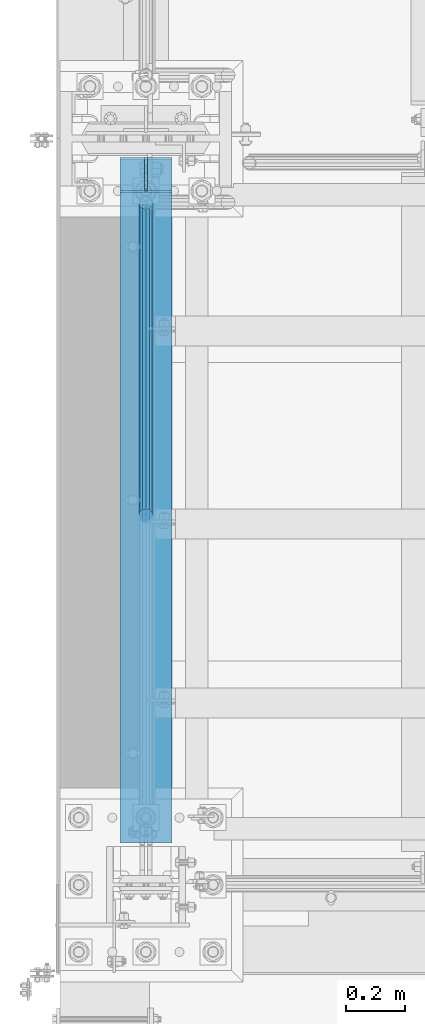
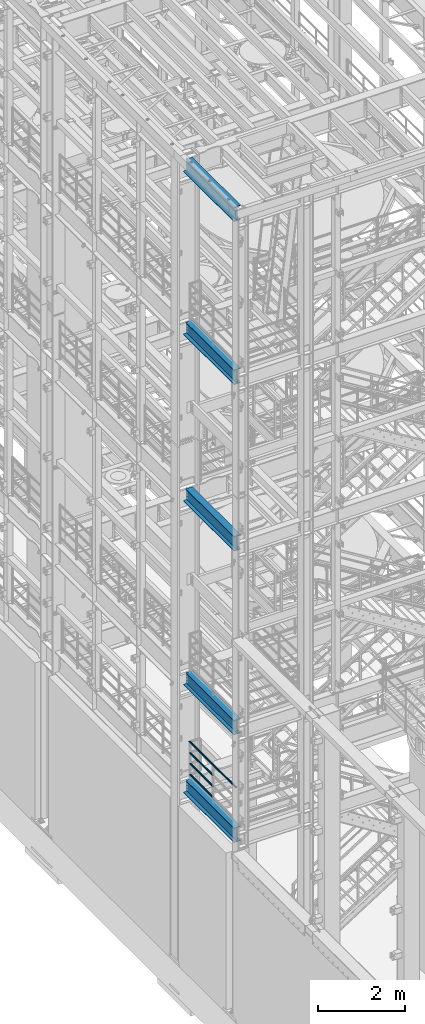
# One storey, part 953 of 1876: 9 beams, 6 elements without a shape of their own.
"""IFC2X3 building model written with IfcOpenShell, lengths in millimetres."""

import ifcopenshell
import ifcopenshell.guid

model = None  # the IFC model being written
_history = None  # IfcOwnerHistory: only IFC2X3 demands one
_inside = {}  # id of a spatial element -> (the spatial element, [elements in it])
_under = {}  # id of a project, library or spatial element -> (it, [spatial elements below it])
_declared = {}  # id of a project -> (the project, [libraries it declares])
_typed = {}  # id of a type object -> (the type object, [elements of that type])
_made_of = {}  # id of a material, layer set ... -> (it, [elements and type objects made of it])


def new_model(schema):
    """Start an empty IFC model of exactly this schema.

    Asked for "IFC4X3", IfcOpenShell would pick the latest addendum, in which some entities
    have other attributes; the version numbers below select the first issue.
    IFC2X3 requires an IfcOwnerHistory on every rooted entity: one is made here for all.
    """
    global model, _history
    if schema == "IFC4X3":
        model = ifcopenshell.file(schema_version=(4, 3, 0, 0))
    else:
        model = ifcopenshell.file(schema=schema)
    _inside.clear()
    _under.clear()
    _declared.clear()
    _typed.clear()
    _made_of.clear()
    _history = None
    if model.schema == "IFC2X3":
        org = make("IfcOrganization", Name="unknown")
        user = make(
            "IfcPersonAndOrganization",
            ThePerson=make("IfcPerson", FamilyName="unknown"),
            TheOrganization=org,
        )
        app = make(
            "IfcApplication",
            ApplicationDeveloper=org,
            Version="unknown",
            ApplicationFullName="unknown",
            ApplicationIdentifier="unknown",
        )
        _history = make(
            "IfcOwnerHistory",
            OwningUser=user,
            OwningApplication=app,
            ChangeAction="ADDED",
            CreationDate=0,
        )
    return model


def make(cls, **values):
    """One entity of the class cls with the attributes given. An attribute that is None is left unset."""
    return model.create_entity(
        cls, **{name: value for name, value in values.items() if value is not None}
    )


def rooted(cls, **values):
    """An entity with a GlobalId (a new one), such as an element, a storey or a relation."""
    return make(cls, GlobalId=ifcopenshell.guid.new(), OwnerHistory=_history, **values)


def si_unit(unit_type, name, prefix=None):
    """IfcSIUnit, for example si_unit("LENGTHUNIT", "METRE", prefix="MILLI")."""
    return make("IfcSIUnit", UnitType=unit_type, Prefix=prefix, Name=name)


def assignment(units):
    """IfcUnitAssignment: the units of a project."""
    return None if units is None else make("IfcUnitAssignment", Units=units)


def point(xyz):
    """IfcCartesianPoint."""
    return None if xyz is None else make("IfcCartesianPoint", Coordinates=xyz)


def direction(xyz):
    """IfcDirection."""
    return None if xyz is None else make("IfcDirection", DirectionRatios=xyz)


def frame(location, z_axis=None, x_axis=None):
    """IfcAxis2Placement3D, a coordinate frame: its origin and axes. An axis left out is left unset."""
    return make(
        "IfcAxis2Placement3D",
        Location=point(location),
        Axis=direction(z_axis),
        RefDirection=direction(x_axis),
    )


def origin_with_axes():
    """The frame at (0, 0, 0) with the z axis (0, 0, 1) and the x axis (1, 0, 0) written out."""
    return frame((0.0, 0.0, 0.0), z_axis=(0.0, 0.0, 1.0), x_axis=(1.0, 0.0, 0.0))


def place(relative_to, where):
    """IfcLocalPlacement: puts the frame where relative to a parent placement (None: the world)."""
    return make(
        "IfcLocalPlacement", PlacementRelTo=relative_to, RelativePlacement=where
    )


def context(
    kind, dimensions, precision=None, world=None, true_north=None, identifier=None
):
    """IfcGeometricRepresentationContext, for example the 3D "Model" context."""
    return make(
        "IfcGeometricRepresentationContext",
        ContextIdentifier=identifier,
        ContextType=kind,
        CoordinateSpaceDimension=dimensions,
        Precision=precision,
        WorldCoordinateSystem=world,
        TrueNorth=true_north,
    )


def subcontext(parent, identifier, kind, view, scale=None):
    """IfcGeometricRepresentationSubContext, for example "Body" below "Model"."""
    return make(
        "IfcGeometricRepresentationSubContext",
        ContextIdentifier=identifier,
        ContextType=kind,
        ParentContext=parent,
        TargetScale=scale,
        TargetView=view,
    )


def project(units=None, contexts=None):
    """IfcProject with its units and contexts."""
    return rooted(
        "IfcProject",
        Name="project",
        RepresentationContexts=contexts,
        UnitsInContext=assignment(units),
    )


def spatial(cls, under=None, at=None, **own):
    """A site, building, storey or space (cls), placed at a placement, below another one or the project."""
    s = rooted(cls, ObjectPlacement=at, **own)
    if under is not None:
        _under.setdefault(under.id(), (under, []))[1].append(s)
    return s


def faces_of(points, faces, orient=None, outer=None):
    """IfcFace entities. A face is a list of loops; a loop is a list of indices into points, from 0.

    orient and outer hold one flag for each loop. By default every Orientation is true, the
    first loop of a face is its IfcFaceOuterBound and the others are IfcFaceBound.
    """
    made = []
    for i, loops in enumerate(faces):
        bounds = []
        for j, loop in enumerate(loops):
            is_outer = j == 0 if outer is None else outer[i][j]
            bounds.append(
                make(
                    "IfcFaceOuterBound" if is_outer else "IfcFaceBound",
                    Bound=make("IfcPolyLoop", Polygon=[points[k] for k in loop]),
                    Orientation=True if orient is None else orient[i][j],
                )
            )
        made.append(make("IfcFace", Bounds=bounds))
    return made


def faceted_brep(points, faces, orient=None, outer=None, voids=None):
    """IfcFacetedBrep: a solid bounded by flat faces; with voids (closed shells), ...WithVoids."""
    shared = [point(p) for p in points]
    hull = make("IfcClosedShell", CfsFaces=faces_of(shared, faces, orient, outer))
    if voids is None:
        return make("IfcFacetedBrep", Outer=hull)
    return make(
        "IfcFacetedBrepWithVoids",
        Outer=hull,
        Voids=[
            make(cls, CfsFaces=faces_of(shared, fs, o, b)) for cls, fs, o, b in voids
        ],
    )


def shape(context_of_items, identifier, shape_type, items):
    """IfcShapeRepresentation: the items that make up one representation, for example the "Body"."""
    return make(
        "IfcShapeRepresentation",
        ContextOfItems=context_of_items,
        RepresentationIdentifier=identifier,
        RepresentationType=shape_type,
        Items=items,
    )


def material(Name=None, Category=None):
    """IfcMaterial."""
    return make("IfcMaterial", Name=Name, Category=Category)


def made_of(thing, what):
    """Note that an element or type object is made of a material, layer set ...; save() writes the relation."""
    if what is not None:
        _made_of.setdefault(what.id(), (what, []))[1].append(thing)
    return thing


def type_object(cls, material=None, **own):
    """A type object (cls), such as IfcWallType, which elements share."""
    return made_of(rooted(cls, **own), material)


def element(
    cls,
    number,
    at=None,
    inside=None,
    cuts=None,
    type_object=None,
    material=None,
    context=None,
    identifier="Body",
    shape_type=None,
    held_by="IfcProductDefinitionShape",
    body=None,
    shapes=None,
    **own,
):
    """One element of the class cls, such as IfcWall. Its Tag is "e" and its number.

    at: its placement. inside: the storey or other place that contains it. cuts: it is an
    opening in that element (IfcRelVoidsElement). A single representation is given by context,
    identifier, shape_type and body (its items); several are given by shapes. held_by: the class
    of the entity that holds the representations. save() writes the other relations.
    """
    e = rooted(cls, Tag="e%d" % number, ObjectPlacement=at, **own)
    if body is not None:
        shapes = [shape(context, identifier, shape_type, body)]
    if shapes is not None:
        e.Representation = make(held_by, Representations=shapes)
    if inside is not None:
        _inside.setdefault(inside.id(), (inside, []))[1].append(e)
    if cuts is not None:
        rooted(
            "IfcRelVoidsElement", RelatingBuildingElement=cuts, RelatedOpeningElement=e
        )
    if type_object is not None:
        _typed.setdefault(type_object.id(), (type_object, []))[1].append(e)
    return made_of(e, material)


def aggregate(whole, parts):
    """IfcRelAggregates: a whole, such as a stair, and the parts it consists of."""
    return rooted("IfcRelAggregates", RelatingObject=whole, RelatedObjects=parts)


def save(model, path):
    """Write the relations noted so far, then the file.

    IfcRelAggregates (storeys below a building ...), IfcRelContainedInSpatialStructure (elements
    in a storey), IfcRelDefinesByType, IfcRelAssociatesMaterial and IfcRelDeclares: one each for
    every whole, place, type object, material and project.
    """
    for whole, parts in _under.values():
        aggregate(whole, parts)
    for where, things in _inside.values():
        rooted(
            "IfcRelContainedInSpatialStructure",
            RelatedElements=things,
            RelatingStructure=where,
        )
    for kind, things in _typed.values():
        rooted("IfcRelDefinesByType", RelatedObjects=things, RelatingType=kind)
    for what, things in _made_of.values():
        rooted("IfcRelAssociatesMaterial", RelatedObjects=things, RelatingMaterial=what)
    for by, libraries in _declared.values():
        rooted("IfcRelDeclares", RelatingContext=by, RelatedDefinitions=libraries)
    model.write(path)


model = new_model("IFC2X3")

# Units and contexts
model_context = context("Model", 3, precision=1e-05, world=origin_with_axes())
body_context = subcontext(model_context, "Body", "Model", "MODEL_VIEW")
ifc_project = project(units=[si_unit("LENGTHUNIT", "METRE", prefix="MILLI"), si_unit("AREAUNIT", "SQUARE_METRE"), si_unit("VOLUMEUNIT", "CUBIC_METRE"), si_unit("MASSUNIT", "GRAM", prefix="KILO"), si_unit("TIMEUNIT", "SECOND"), si_unit("PLANEANGLEUNIT", "RADIAN"), si_unit("SOLIDANGLEUNIT", "STERADIAN"), si_unit("THERMODYNAMICTEMPERATUREUNIT", "DEGREE_CELSIUS"), si_unit("LUMINOUSINTENSITYUNIT", "LUMEN")], contexts=[model_context])

# Site, building, storey
site_placement = place(None, origin_with_axes())
site = spatial("IfcSite", under=ifc_project, at=site_placement, CompositionType="ELEMENT")
building_placement = place(site_placement, origin_with_axes())
building = spatial("IfcBuilding", under=site, at=building_placement, Name="Undefined", CompositionType="ELEMENT")
storey_placement = place(building_placement, origin_with_axes())
storey = spatial("IfcBuildingStorey", under=building, at=storey_placement, Name="Undefined", CompositionType="ELEMENT", Elevation=0.0)

# Assembly, beams
assembly_1_placement = place(storey_placement, origin_with_axes())
assembly_1 = element("IfcElementAssembly", 1, at=assembly_1_placement, inside=storey, Name="RAIL", AssemblyPlace="NOTDEFINED", PredefinedType="RIGID_FRAME")
ifc_material_1 = material()
beam_type_1 = type_object("IfcBeamType", Name="PIPE1-1/2SCH40", PredefinedType="NOTDEFINED")
beam_1_placement = place(assembly_1_placement, frame((-4.25200314889665e-12, -4788.2175, 5292.725), z_axis=(0.0, 0.0, 1.0), x_axis=(0.0, -1.0, 0.0)))
beam_1 = element("IfcBeam", 2, at=beam_1_placement, type_object=beam_type_1, material=ifc_material_1, Name="RAIL", ObjectType="PIPE1-1/2SCH40", context=body_context, shape_type="Brep", body=[
    faceted_brep([(1047.96655700668, -12.0649999999996, 20.8971929933177), (1047.96655700668, -12.0649999999787, 15.8661214312015), (1047.47312856882, -10.2235000000001, 17.7076214311819), (1044.73375, 9.09494701772928e-13, 20.4470000000001), (1044.73375, 9.09494701772928e-13, 24.130000000001), (1047.47312856881, 10.2235000000001, 17.7076214311819), (1047.96655700668, 12.0650000000205, 15.8661214311578), (1047.96655700668, 12.0649999999996, 20.8971929933177), (1068.86375, 24.1300000000001, 0.0), (1056.79875, 20.8971929933186, 12.0649999999987), (1056.79875, 20.8971929933186, -12.0649999999987), (1053.60917843784, 17.7076214311801, 10.2235000000001), (1056.34855700666, 20.4470000000001, 0.0), (1053.60917843784, 17.7076214311801, -10.2235000000001), (1047.96655700668, 12.0650000000205, -15.8661214311578), (1047.96655700668, 12.0649999999996, -20.8971929933177), (1047.47312856881, 10.2235000000001, -17.7076214311819), (1044.73375, 0.0, -20.4470000000001), (1044.73375, 0.0, -24.130000000001), (1047.96655700668, -12.0649999999787, -15.8661214312015), (1047.96655700668, -12.0649999999996, -20.8971929933177), (1047.47312856882, -10.2235000000001, -17.7076214311819), (1068.86375, -24.1299999999792, 0.0), (1056.79875, -20.8971929933186, -12.0649999999987), (1056.79875, -20.8971929933186, 12.0649999999987), (1053.60917843788, -17.7076214311801, -10.2235000000001), (1056.3485570067, -20.4470000000001, 0.0), (1053.60917843788, -17.7076214311801, 10.2235000000001), (12.0650000000064, -20.8971929933177, -12.0649999999987), (20.8971929933249, -12.0650000000005, -20.8971929933177), (0.0, 24.1299999999992, 0.0), (12.0650000000064, 20.8971929933177, -12.0649999999987), (12.0650000000064, 20.8971929933177, 12.0649999999987), (20.8971929933249, 12.0650000000005, 20.8971929933177), (24.1300000000064, 0.0, 24.130000000001), (20.8971929933249, 12.0650000000005, -20.8971929933177), (24.1300000000063, 0.0, -24.130000000001), (24.1300000000063, 0.0, -20.4470000000001), (20.8971929933249, -12.0650000000005, -15.8661214311796), (21.3906214311868, -10.2235000000001, -17.7076214311819), (21.3906214311868, 10.2235000000001, -17.7076214311819), (20.8971929933249, 12.0650000000005, -15.8661214311796), (15.2545715621445, 17.7076214311801, -10.2235000000001), (12.5151929933249, 20.4470000000001, 0.0), (15.2545715621445, 17.7076214311801, 10.2235000000001), (20.8971929933249, 12.0650000000005, 15.8661214311796), (21.3906214311868, 10.2235000000001, 17.7076214311819), (24.1300000000064, 0.0, 20.4470000000001), (21.3906214311868, -10.2235000000001, 17.7076214311819), (20.8971929933249, -12.0650000000005, 15.8661214311796), (20.8971929933249, -12.0650000000005, 20.8971929933177), (12.0650000000064, -20.8971929933177, 12.0649999999987), (0.0, -24.1299999999992, 0.0), (15.2545715621445, -17.7076214311801, 10.2235000000001), (12.5151929933249, -20.4470000000001, 0.0), (15.2545715621445, -17.7076214311801, -10.2235000000001)], [[[0, 1, 2, 3, 4]], [[4, 3, 5, 6, 7]], [[8, 9, 10]], [[7, 6, 11, 12, 13, 14, 15, 10, 9]], [[16, 17, 18, 15, 14]], [[19, 20, 18, 17, 21]], [[22, 23, 24]], [[24, 23, 20, 19, 25, 26, 27, 1, 0]], [[28, 29, 20, 23]], [[30, 31, 32]], [[33, 34, 4, 7]], [[32, 33, 7, 9]], [[30, 32, 9, 8]], [[31, 30, 8, 10]], [[35, 31, 10, 15]], [[36, 35, 15, 18]], [[29, 36, 18, 20]], [[37, 36, 29, 38, 39]], [[40, 41, 35, 36, 37]], [[32, 31, 35, 41, 42, 43, 44, 45, 33]], [[33, 45, 46, 47, 34]], [[34, 47, 48, 49, 50]], [[34, 50, 0, 4]], [[50, 51, 24, 0]], [[51, 52, 22, 24]], [[52, 28, 23, 22]], [[51, 28, 52]], [[50, 49, 53, 54, 55, 38, 29, 28, 51]], [[55, 54, 26, 25]], [[21, 39, 38, 55, 25, 19]], [[37, 39, 21, 17]], [[40, 37, 17, 16]], [[42, 41, 40, 16, 14, 13]], [[43, 42, 13, 12]], [[44, 43, 12, 11]], [[5, 46, 45, 44, 11, 6]], [[47, 46, 5, 3]], [[48, 47, 3, 2]], [[53, 49, 48, 2, 1, 27]], [[54, 53, 27, 26]]]),
])
beam_2_placement = place(assembly_1_placement, frame((-6.99174051987939e-10, -5857.08125, 5597.52500110486), z_axis=(0.0, 0.0, -1.0), x_axis=(0.0, 1.0, 0.0)))
beam_2 = element("IfcBeam", 3, at=beam_2_placement, type_object=beam_type_1, material=ifc_material_1, Name="RAIL", ObjectType="PIPE1-1/2SCH40", context=body_context, shape_type="Brep", body=[
    faceted_brep([(0.0, 24.1299999999992, 0.0), (12.0650000000064, 20.8971929933177, -12.0649999999987), (12.0650000000064, 20.8971929933177, 12.0649999999987), (12.0650000000064, -20.8971929933177, 12.0649999999987), (12.0650000000064, -20.8971929933177, -12.0649999999987), (0.0, -24.1299999999992, 0.0), (20.8971929933249, -12.0650000000005, 20.8971929933177), (20.8971929933249, -12.0650000000005, 15.8661214311796), (15.2545715621445, -17.7076214311801, 10.2235000000001), (12.5151929933249, -20.4470000000001, 0.0), (15.2545715621445, -17.7076214311801, -10.2235000000001), (20.8971929933249, -12.0650000000005, -15.8661214311796), (20.8971929933249, -12.0650000000005, -20.8971929933177), (24.1300000000063, 0.0, -20.4470000000001), (24.1300000000063, 0.0, -24.130000000001), (21.3906214311868, -10.2235000000001, -17.7076214311819), (21.3906214311868, 10.2235000000001, -17.7076214311819), (20.8971929933249, 12.0650000000005, -15.8661214311796), (20.8971929933249, 12.0650000000005, -20.8971929933177), (15.2545715621445, 17.7076214311801, -10.2235000000001), (12.5151929933249, 20.4470000000001, 0.0), (15.2545715621445, 17.7076214311801, 10.2235000000001), (20.8971929933249, 12.0650000000005, 15.8661214311796), (20.8971929933249, 12.0650000000005, 20.8971929933177), (21.3906214311868, 10.2235000000001, 17.7076214311819), (24.1300000000064, 0.0, 20.4470000000001), (24.1300000000064, 0.0, 24.130000000001), (21.3906214311868, -10.2235000000001, 17.7076214311819), (1068.86375, 24.1300000000001, 0.0), (1056.79875, 20.8971929933186, -12.0649999999987), (1047.96655700668, 12.0649999999996, -20.8971929933177), (1068.86375, -24.1299999999792, 0.0), (1056.79875, -20.8971929933186, -12.0649999999987), (1056.79875, -20.8971929933186, 12.0649999999987), (1047.96655700668, -12.0649999999996, 20.8971929933177), (1047.96655700668, -12.0649999999996, -20.8971929933177), (1044.73375, 0.0, -24.130000000001), (1047.47312856881, 10.2235000000001, -17.7076214311819), (1044.73375, 0.0, -20.4470000000001), (1047.96655700668, 12.0650000000205, -15.8661214311578), (1047.96655700668, -12.0649999999787, -15.8661214312015), (1047.47312856882, -10.2235000000001, -17.7076214311819), (1053.60917843788, -17.7076214311801, -10.2235000000001), (1056.3485570067, -20.4470000000001, 0.0), (1053.60917843788, -17.7076214311801, 10.2235000000001), (1047.96655700668, -12.0649999999787, 15.8661214312015), (1047.47312856882, -10.2235000000001, 17.7076214311819), (1044.73375, 9.09494701772928e-13, 20.4470000000001), (1044.73375, 9.09494701772928e-13, 24.130000000001), (1047.96655700668, 12.0649999999996, 20.8971929933177), (1056.79875, 20.8971929933186, 12.0649999999987), (1047.96655700668, 12.0650000000205, 15.8661214311578), (1053.60917843784, 17.7076214311801, 10.2235000000001), (1056.34855700666, 20.4470000000001, 0.0), (1053.60917843784, 17.7076214311801, -10.2235000000001), (1047.47312856881, 10.2235000000001, 17.7076214311819)], [[[0, 1, 2]], [[3, 4, 5]], [[6, 7, 8, 9, 10, 11, 12, 4, 3]], [[13, 14, 12, 11, 15]], [[16, 17, 18, 14, 13]], [[2, 1, 18, 17, 19, 20, 21, 22, 23]], [[23, 22, 24, 25, 26]], [[26, 25, 27, 7, 6]], [[1, 0, 28, 29]], [[18, 1, 29, 30]], [[31, 32, 33]], [[6, 3, 33, 34]], [[3, 5, 31, 33]], [[5, 4, 32, 31]], [[4, 12, 35, 32]], [[12, 14, 36, 35]], [[14, 18, 30, 36]], [[37, 38, 36, 30, 39]], [[40, 35, 36, 38, 41]], [[33, 32, 35, 40, 42, 43, 44, 45, 34]], [[34, 45, 46, 47, 48]], [[26, 6, 34, 48]], [[2, 23, 49, 50]], [[23, 26, 48, 49]], [[0, 2, 50, 28]], [[28, 50, 29]], [[49, 51, 52, 53, 54, 39, 30, 29, 50]], [[48, 47, 55, 51, 49]], [[25, 24, 55, 47]], [[55, 24, 22, 21, 52, 51]], [[21, 20, 53, 52]], [[20, 19, 54, 53]], [[19, 17, 16, 37, 39, 54]], [[16, 13, 38, 37]], [[13, 15, 41, 38]], [[41, 15, 11, 10, 42, 40]], [[10, 9, 43, 42]], [[9, 8, 44, 43]], [[8, 7, 27, 46, 45, 44]], [[27, 25, 47, 46]]]),
])
beam_3_placement = place(assembly_1_placement, frame((-3.46290107700042e-10, -5857.08125, 5902.3250011048), z_axis=(0.0, 0.0, -1.0), x_axis=(0.0, 1.0, 0.0)))
beam_3 = element("IfcBeam", 4, at=beam_3_placement, type_object=beam_type_1, material=ifc_material_1, Name="RAIL", ObjectType="PIPE1-1/2SCH40", context=body_context, shape_type="Brep", body=[
    faceted_brep([(0.0, 24.1299999999992, 0.0), (12.0650000000064, 20.8971929933177, -12.0649999999987), (12.0650000000064, 20.8971929933177, 12.0649999999987), (12.0650000000064, -20.8971929933177, 12.0649999999987), (12.0650000000064, -20.8971929933177, -12.0649999999987), (0.0, -24.1299999999992, 0.0), (20.8971929933249, -12.0650000000005, 20.8971929933177), (20.8971929933249, -12.0650000000005, 15.8661214311796), (15.2545715621445, -17.7076214311801, 10.2235000000001), (12.5151929933249, -20.4470000000001, 0.0), (15.2545715621445, -17.7076214311801, -10.2235000000001), (20.8971929933249, -12.0650000000005, -15.8661214311796), (20.8971929933249, -12.0650000000005, -20.8971929933177), (24.1300000000063, 0.0, -20.4470000000001), (24.1300000000063, 0.0, -24.130000000001), (21.3906214311868, -10.2235000000001, -17.7076214311819), (21.3906214311868, 10.2235000000001, -17.7076214311819), (20.8971929933249, 12.0650000000005, -15.8661214311796), (20.8971929933249, 12.0650000000005, -20.8971929933177), (15.2545715621445, 17.7076214311801, -10.2235000000001), (12.5151929933249, 20.4470000000001, 0.0), (15.2545715621445, 17.7076214311801, 10.2235000000001), (20.8971929933249, 12.0650000000005, 15.8661214311796), (20.8971929933249, 12.0650000000005, 20.8971929933177), (21.3906214311868, 10.2235000000001, 17.7076214311819), (24.1300000000064, 0.0, 20.4470000000001), (24.1300000000064, 0.0, 24.130000000001), (21.3906214311868, -10.2235000000001, 17.7076214311819), (1068.86375, 24.1300000000001, 0.0), (1056.79875, 20.8971929933186, -12.0649999999987), (1047.96655700668, 12.0649999999996, -20.8971929933177), (1068.86375, -24.1299999999792, 0.0), (1056.79875, -20.8971929933186, -12.0649999999987), (1056.79875, -20.8971929933186, 12.0649999999987), (1047.96655700668, -12.0649999999996, 20.8971929933177), (1047.96655700668, -12.0649999999996, -20.8971929933177), (1044.73375, 0.0, -24.130000000001), (1047.47312856881, 10.2235000000001, -17.7076214311819), (1044.73375, 0.0, -20.4470000000001), (1047.96655700668, 12.0650000000205, -15.8661214311578), (1047.96655700668, -12.0649999999787, -15.8661214312015), (1047.47312856882, -10.2235000000001, -17.7076214311819), (1053.60917843788, -17.7076214311801, -10.2235000000001), (1056.3485570067, -20.4470000000001, 0.0), (1053.60917843788, -17.7076214311801, 10.2235000000001), (1047.96655700668, -12.0649999999787, 15.8661214312015), (1047.47312856882, -10.2235000000001, 17.7076214311819), (1044.73375, 9.09494701772928e-13, 20.4470000000001), (1044.73375, 9.09494701772928e-13, 24.130000000001), (1047.96655700668, 12.0649999999996, 20.8971929933177), (1056.79875, 20.8971929933186, 12.0649999999987), (1047.96655700668, 12.0650000000205, 15.8661214311578), (1053.60917843784, 17.7076214311801, 10.2235000000001), (1056.34855700666, 20.4470000000001, 0.0), (1053.60917843784, 17.7076214311801, -10.2235000000001), (1047.47312856881, 10.2235000000001, 17.7076214311819)], [[[0, 1, 2]], [[3, 4, 5]], [[6, 7, 8, 9, 10, 11, 12, 4, 3]], [[13, 14, 12, 11, 15]], [[16, 17, 18, 14, 13]], [[2, 1, 18, 17, 19, 20, 21, 22, 23]], [[23, 22, 24, 25, 26]], [[26, 25, 27, 7, 6]], [[1, 0, 28, 29]], [[18, 1, 29, 30]], [[31, 32, 33]], [[6, 3, 33, 34]], [[3, 5, 31, 33]], [[5, 4, 32, 31]], [[4, 12, 35, 32]], [[12, 14, 36, 35]], [[14, 18, 30, 36]], [[37, 38, 36, 30, 39]], [[40, 35, 36, 38, 41]], [[33, 32, 35, 40, 42, 43, 44, 45, 34]], [[34, 45, 46, 47, 48]], [[26, 6, 34, 48]], [[2, 23, 49, 50]], [[23, 26, 48, 49]], [[0, 2, 50, 28]], [[28, 50, 29]], [[49, 51, 52, 53, 54, 39, 30, 29, 50]], [[48, 47, 55, 51, 49]], [[25, 24, 55, 47]], [[55, 24, 22, 21, 52, 51]], [[21, 20, 53, 52]], [[20, 19, 54, 53]], [[19, 17, 16, 37, 39, 54]], [[16, 13, 38, 37]], [[13, 15, 41, 38]], [[41, 15, 11, 10, 42, 40]], [[10, 9, 43, 42]], [[9, 8, 44, 43]], [[8, 7, 27, 46, 45, 44]], [[27, 25, 47, 46]]]),
])
beam_4_placement = place(assembly_1_placement, frame((-1.62344804266468e-10, -6950.075, 6207.1250021491), z_axis=(0.0, 0.0, -1.0), x_axis=(0.0, 1.0, 0.0)))
beam_4 = element("IfcBeam", 5, at=beam_4_placement, type_object=beam_type_1, material=ifc_material_1, Name="RAIL", ObjectType="PIPE1-1/2SCH40", context=body_context, shape_type="Brep", body=[
    faceted_brep([(24.1300000000001, -20.4469999999999, 0.0), (34.3535000000002, -17.7076214311803, 10.2235000000001), (2179.56512143117, -17.7076214311804, 10.2235000000001), (2182.30449999999, -20.447, 0.0), (41.8376214311802, -10.2235000000001, 17.7076214311819), (2172.08099999999, -10.2235, 17.7076214311819), (44.5770000000002, 0.0, 20.4470000000001), (2161.8575, 0.0, 20.4470000000001), (41.8376214311802, 10.2235000000001, 17.7076214311819), (2151.63399999999, 10.2235, 17.7076214311819), (34.3535000000002, 17.7076214311803, 10.2235000000001), (2144.14987856881, 17.7076214311804, 10.2235000000001), (24.1300000000001, 20.4469999999999, 0.0), (2141.41049999999, 20.447, 0.0), (13.9065000000001, 17.7076214311803, -10.2235000000001), (2144.14987856881, 17.7076214311804, -10.2235000000001), (6.42237856882002, 10.2235000000001, -17.7076214311819), (2151.63399999999, 10.2235, -17.7076214311819), (3.68299999999999, 0.0, -20.4470000000001), (2161.8575, 0.0, -20.4470000000001), (6.42237856882002, -10.2235000000001, -17.7076214311819), (2172.08099999999, -10.2235, -17.7076214311819), (13.9065000000001, -17.7076214311803, -10.2235000000001), (2179.56512143117, -17.7076214311804, -10.2235000000001), (24.1299999999854, -24.1299999999992, 0.0), (12.0650000000064, -20.8971929933177, -12.0649999999987), (2182.75469299331, -20.8971929933185, -12.0649999999987), (2185.98749999999, -24.13, 0.0), (3.23280700668147, -12.0650000000001, -20.8971929933177), (2173.9225, -12.065, -20.8971929933177), (-1.45519152283669e-11, 0.0, -24.130000000001), (2161.8575, 0.0, -24.130000000001), (3.23280700668147, 12.0650000000001, -20.8971929933177), (2149.79249999999, 12.065, -20.8971929933177), (12.0650000000064, 20.8971929933177, -12.0649999999987), (2140.96030700668, 20.8971929933185, -12.0649999999987), (24.1300000000047, 24.1299999999992, 0.0), (2137.72749999999, 24.13, 0.0), (36.1949999999997, 20.8971929933184, 12.0649999999987), (2140.96030700668, 20.8971929933185, 12.0649999999987), (45.0271929933187, 12.0650000000001, 20.8971929933177), (2149.79249999999, 12.065, 20.8971929933177), (48.2600000000002, 0.0, 24.130000000001), (2161.8575, 0.0, 24.130000000001), (45.0271929933187, -12.0650000000001, 20.8971929933177), (2173.9225, -12.065, 20.8971929933177), (36.1949999999997, -20.8971929933184, 12.0649999999987), (2182.75469299331, -20.8971929933185, 12.0649999999987)], [[[0, 1, 2, 3]], [[1, 4, 5, 2]], [[4, 6, 7, 5]], [[6, 8, 9, 7]], [[8, 10, 11, 9]], [[10, 12, 13, 11]], [[12, 14, 15, 13]], [[14, 16, 17, 15]], [[16, 18, 19, 17]], [[18, 20, 21, 19]], [[20, 22, 23, 21]], [[22, 0, 3, 23]], [[24, 25, 26, 27]], [[25, 28, 29, 26]], [[28, 30, 31, 29]], [[30, 32, 33, 31]], [[32, 34, 35, 33]], [[34, 36, 37, 35]], [[36, 38, 39, 37]], [[38, 40, 41, 39]], [[40, 42, 43, 41]], [[42, 44, 45, 43]], [[44, 46, 47, 45]], [[46, 24, 27, 47]], [[29, 31, 33, 35, 37, 39, 41, 43, 45, 47, 27, 26], [5, 7, 9, 11, 13, 15, 17, 19, 21, 23, 3, 2]], [[46, 44, 42, 40, 38, 36, 34, 32, 30, 28, 25, 24], [22, 20, 18, 16, 14, 12, 10, 8, 6, 4, 1, 0]]]),
])
aggregate(assembly_1, [beam_1, beam_2, beam_3, beam_4])

# Assembly, beam
assembly_2_placement = place(storey_placement, origin_with_axes())
assembly_2 = element("IfcElementAssembly", 6, at=assembly_2_placement, inside=storey, Name="BEAM", AssemblyPlace="NOTDEFINED", PredefinedType="RIGID_FRAME")
ifc_material_2 = material(Name="STEEL/A992")
beam_type_2 = type_object("IfcBeamType", Name="W16X45", PredefinedType="NOTDEFINED")
beam_5_placement = place(assembly_2_placement, frame((0.0, -7112.0, 17778.4125), z_axis=(0.0, 0.0, 1.0), x_axis=(0.0, 1.0, 0.0)))
beam_5 = element("IfcBeam", 7, at=beam_5_placement, type_object=beam_type_2, material=ifc_material_2, Name="BEAM", ObjectType="W16X45", context=body_context, shape_type="Brep", body=[
    faceted_brep([(2362.99375, -88.8999999999996, 204.787499999999), (2362.99375, -88.8999999999996, 190.5), (2362.99375, -4.76249999999982, 190.5), (2362.99375, -4.76249999999982, 166.427501487731), (2362.99375, 4.76249999999982, 166.427501487731), (2362.99375, 4.76249999999982, 190.5), (2362.99375, 88.8999999999996, 190.5), (2362.99375, 88.8999999999996, 204.787499999999), (2363.96047992259, -4.76249999999982, 161.567421969685), (2363.96047992259, 4.76249999999982, 161.567421969685), (2366.71349382307, -4.76249999999982, 157.447245501531), (2366.71349382307, 4.76249999999982, 157.447245501531), (2370.83367029122, -4.76249999999982, 154.694231601054), (2370.83367029122, 4.76249999999982, 154.694231601054), (2375.69374980926, -4.76249999999982, 153.727501678466), (2375.69374980926, 4.76249999999982, 153.727501678466), (2477.29375, -4.76249999999982, 153.727501678466), (2477.29375, 4.76249999999982, 153.727501678466), (142.875, -88.8999999999996, -204.787499999999), (142.875, -88.8999999999996, -190.5), (142.875, -4.76249999999982, -190.5), (142.875, -4.76249999999982, 190.5), (142.875, -88.8999999999996, 190.5), (142.875, -88.8999999999996, 204.787499999999), (142.875, 88.8999999999996, 204.787499999999), (142.875, 88.8999999999996, 190.5), (142.875, 4.76249999999982, 190.5), (142.875, 4.76249999999982, -190.5), (142.875, 88.8999999999996, -190.5), (142.875, 88.8999999999996, -204.787499999999), (2477.29375, 4.76249999999982, -190.5), (2477.29375, 88.8999999999996, -190.5), (2477.29375, 88.8999999999996, -204.787499999999), (2477.29375, -88.8999999999996, -204.787499999999), (2477.29375, -88.8999999999996, -190.5), (2477.29375, -4.76249999999982, -190.5)], [[[0, 1, 2, 3, 4, 5, 6, 7]], [[8, 9, 4, 3]], [[10, 11, 9, 8]], [[12, 13, 11, 10]], [[14, 15, 13, 12]], [[16, 17, 15, 14]], [[18, 19, 20, 21, 22, 23, 24, 25, 26, 27, 28, 29]], [[28, 27, 30, 31]], [[29, 28, 31, 32]], [[18, 29, 32, 33]], [[19, 18, 33, 34]], [[20, 19, 34, 35]], [[12, 10, 8, 3, 2, 21, 20, 35, 16, 14]], [[22, 21, 2, 1]], [[23, 22, 1, 0]], [[24, 23, 0, 7]], [[25, 24, 7, 6]], [[26, 25, 6, 5]], [[30, 27, 26, 5, 4, 9, 11, 13, 15, 17]], [[35, 34, 33, 32, 31, 30, 17, 16]]]),
])
aggregate(assembly_2, [beam_5])

assembly_3_placement = place(storey_placement, origin_with_axes())
assembly_3 = element("IfcElementAssembly", 8, at=assembly_3_placement, inside=storey, Name="BEAM", AssemblyPlace="NOTDEFINED", PredefinedType="RIGID_FRAME")
beam_6_placement = place(assembly_3_placement, frame((0.0, -7112.0, 13104.8125), z_axis=(0.0, 0.0, 1.0), x_axis=(0.0, 1.0, 0.0)))
beam_6 = element("IfcBeam", 9, at=beam_6_placement, type_object=beam_type_2, material=ifc_material_2, Name="BEAM", ObjectType="W16X45", context=body_context, shape_type="Brep", body=[
    faceted_brep([(2362.99375, -88.8999999999996, 204.787499999999), (2362.99375, -88.8999999999996, 190.5), (2362.99375, -4.76249999999982, 190.5), (2362.99375, -4.76249999999982, 166.427501487731), (2362.99375, 4.76249999999982, 166.427501487731), (2362.99375, 4.76249999999982, 190.5), (2362.99375, 88.8999999999996, 190.5), (2362.99375, 88.8999999999996, 204.787499999999), (2363.96047992259, -4.76249999999982, 161.567421969685), (2363.96047992259, 4.76249999999982, 161.567421969685), (2366.71349382307, -4.76249999999982, 157.447245501531), (2366.71349382307, 4.76249999999982, 157.447245501531), (2370.83367029122, -4.76249999999982, 154.694231601054), (2370.83367029122, 4.76249999999982, 154.694231601054), (2375.69374980926, -4.76249999999982, 153.727501678466), (2375.69374980926, 4.76249999999982, 153.727501678466), (2477.29375, -4.76249999999982, 153.727501678466), (2477.29375, 4.76249999999982, 153.727501678466), (142.875, -88.8999999999996, -204.787499999999), (142.875, -88.8999999999996, -190.5), (142.875, -4.76249999999982, -190.5), (142.875, -4.76249999999982, 190.5), (142.875, -88.8999999999996, 190.5), (142.875, -88.8999999999996, 204.787499999999), (142.875, 88.8999999999996, 204.787499999999), (142.875, 88.8999999999996, 190.5), (142.875, 4.76249999999982, 190.5), (142.875, 4.76249999999982, -190.5), (142.875, 88.8999999999996, -190.5), (142.875, 88.8999999999996, -204.787499999999), (2477.29375, 4.76249999999982, -190.5), (2477.29375, 88.8999999999996, -190.5), (2477.29375, 88.8999999999996, -204.787499999999), (2477.29375, -88.8999999999996, -204.787499999999), (2477.29375, -88.8999999999996, -190.5), (2477.29375, -4.76249999999982, -190.5)], [[[0, 1, 2, 3, 4, 5, 6, 7]], [[8, 9, 4, 3]], [[10, 11, 9, 8]], [[12, 13, 11, 10]], [[14, 15, 13, 12]], [[16, 17, 15, 14]], [[18, 19, 20, 21, 22, 23, 24, 25, 26, 27, 28, 29]], [[28, 27, 30, 31]], [[29, 28, 31, 32]], [[18, 29, 32, 33]], [[19, 18, 33, 34]], [[20, 19, 34, 35]], [[12, 10, 8, 3, 2, 21, 20, 35, 16, 14]], [[22, 21, 2, 1]], [[23, 22, 1, 0]], [[24, 23, 0, 7]], [[25, 24, 7, 6]], [[26, 25, 6, 5]], [[30, 27, 26, 5, 4, 9, 11, 13, 15, 17]], [[35, 34, 33, 32, 31, 30, 17, 16]]]),
])
aggregate(assembly_3, [beam_6])

assembly_4_placement = place(storey_placement, origin_with_axes())
assembly_4 = element("IfcElementAssembly", 10, at=assembly_4_placement, inside=storey, Name="BEAM", AssemblyPlace="NOTDEFINED", PredefinedType="RIGID_FRAME")
beam_7_placement = place(assembly_4_placement, frame((0.0, -7112.0, 7948.6125), z_axis=(0.0, 0.0, 1.0), x_axis=(0.0, 1.0, 0.0)))
beam_7 = element("IfcBeam", 11, at=beam_7_placement, type_object=beam_type_2, material=ifc_material_2, Name="BEAM", ObjectType="W16X45", context=body_context, shape_type="Brep", body=[
    faceted_brep([(2356.64375, -88.8999999999996, 204.7875), (2356.64375, -88.8999999999996, 190.5), (2356.64375, -4.76249999999982, 190.5), (2356.64375, -4.76249999999982, 153.727497673035), (2356.64375, 4.76249999999982, 153.727497673035), (2356.64375, 4.76249999999982, 190.5), (2356.64375, 88.8999999999996, 190.5), (2356.64375, 88.8999999999996, 204.7875), (2357.61047992259, -4.76249999999982, 148.86741815499), (2357.61047992259, 4.76249999999982, 148.86741815499), (2360.36349382307, -4.76249999999982, 144.747241686836), (2360.36349382307, 4.76249999999982, 144.747241686836), (2364.48367029122, -4.76249999999982, 141.994227786357), (2364.48367029122, 4.76249999999982, 141.994227786357), (2369.34374980926, -4.76249999999982, 141.02749786377), (2369.34374980926, 4.76249999999982, 141.02749786377), (2470.94375, -4.76249999999982, 141.02749786377), (2470.94375, 4.76249999999982, 141.02749786377), (142.875, -88.8999999999996, -204.787499999999), (142.875, -88.8999999999996, -190.5), (142.875, -4.76249999999982, -190.5), (142.875, -4.76249999999982, 190.5), (142.875, -88.8999999999996, 190.5), (142.875, -88.8999999999996, 204.787499999999), (142.875, 88.8999999999996, 204.787499999999), (142.875, 88.8999999999996, 190.5), (142.875, 4.76249999999982, 190.5), (142.875, 4.76249999999982, -190.5), (142.875, 88.8999999999996, -190.5), (142.875, 88.8999999999996, -204.787499999999), (2470.94375, 4.76249999999982, -190.5), (2470.94375, 88.8999999999996, -190.5), (2470.94375, 88.8999999999996, -204.7875), (2470.94375, -88.8999999999996, -204.7875), (2470.94375, -88.8999999999996, -190.5), (2470.94375, -4.76249999999982, -190.5)], [[[0, 1, 2, 3, 4, 5, 6, 7]], [[8, 9, 4, 3]], [[10, 11, 9, 8]], [[12, 13, 11, 10]], [[14, 15, 13, 12]], [[16, 17, 15, 14]], [[18, 19, 20, 21, 22, 23, 24, 25, 26, 27, 28, 29]], [[28, 27, 30, 31]], [[29, 28, 31, 32]], [[18, 29, 32, 33]], [[19, 18, 33, 34]], [[20, 19, 34, 35]], [[12, 10, 8, 3, 2, 21, 20, 35, 16, 14]], [[22, 21, 2, 1]], [[23, 22, 1, 0]], [[24, 23, 0, 7]], [[25, 24, 7, 6]], [[26, 25, 6, 5]], [[30, 27, 26, 5, 4, 9, 11, 13, 15, 17]], [[35, 34, 33, 32, 31, 30, 17, 16]]]),
])
aggregate(assembly_4, [beam_7])

assembly_5_placement = place(storey_placement, origin_with_axes())
assembly_5 = element("IfcElementAssembly", 12, at=assembly_5_placement, inside=storey, Name="BEAM", AssemblyPlace="NOTDEFINED", PredefinedType="RIGID_FRAME")
beam_8_placement = place(assembly_5_placement, frame((0.0, -7112.0, 22350.4125), z_axis=(0.0, 0.0, 1.0), x_axis=(0.0, 1.0, 0.0)))
beam_8 = element("IfcBeam", 13, at=beam_8_placement, type_object=beam_type_2, material=ifc_material_2, Name="BEAM", ObjectType="W16X45", context=body_context, shape_type="Brep", body=[
    faceted_brep([(2362.99375, -88.8999999999996, 204.787499999999), (2362.99375, -88.8999999999996, 190.5), (2362.99375, -4.76249999999982, 190.5), (2362.99375, -4.76249999999982, 166.427501487731), (2362.99375, 4.76249999999982, 166.427501487731), (2362.99375, 4.76249999999982, 190.5), (2362.99375, 88.8999999999996, 190.5), (2362.99375, 88.8999999999996, 204.787499999999), (2363.96047992259, -4.76249999999982, 161.567421969685), (2363.96047992259, 4.76249999999982, 161.567421969685), (2366.71349382307, -4.76249999999982, 157.447245501531), (2366.71349382307, 4.76249999999982, 157.447245501531), (2370.83367029122, -4.76249999999982, 154.694231601054), (2370.83367029122, 4.76249999999982, 154.694231601054), (2375.69374980926, -4.76249999999982, 153.727501678466), (2375.69374980926, 4.76249999999982, 153.727501678466), (2477.29375, -4.76249999999982, 153.727501678466), (2477.29375, 4.76249999999982, 153.727501678466), (142.875, -88.8999999999996, -204.787499999999), (142.875, -88.8999999999996, -190.5), (142.875, -4.76249999999982, -190.5), (142.875, -4.76249999999982, 190.5), (142.875, -88.8999999999996, 190.5), (142.875, -88.8999999999996, 204.787499999999), (142.875, 88.8999999999996, 204.787499999999), (142.875, 88.8999999999996, 190.5), (142.875, 4.76249999999982, 190.5), (142.875, 4.76249999999982, -190.5), (142.875, 88.8999999999996, -190.5), (142.875, 88.8999999999996, -204.787499999999), (2477.29375, 4.76249999999982, -190.5), (2477.29375, 88.8999999999996, -190.5), (2477.29375, 88.8999999999996, -204.787499999999), (2477.29375, -88.8999999999996, -204.787499999999), (2477.29375, -88.8999999999996, -190.5), (2477.29375, -4.76249999999982, -190.5)], [[[0, 1, 2, 3, 4, 5, 6, 7]], [[8, 9, 4, 3]], [[10, 11, 9, 8]], [[12, 13, 11, 10]], [[14, 15, 13, 12]], [[16, 17, 15, 14]], [[18, 19, 20, 21, 22, 23, 24, 25, 26, 27, 28, 29]], [[28, 27, 30, 31]], [[29, 28, 31, 32]], [[18, 29, 32, 33]], [[19, 18, 33, 34]], [[20, 19, 34, 35]], [[12, 10, 8, 3, 2, 21, 20, 35, 16, 14]], [[22, 21, 2, 1]], [[23, 22, 1, 0]], [[24, 23, 0, 7]], [[25, 24, 7, 6]], [[26, 25, 6, 5]], [[30, 27, 26, 5, 4, 9, 11, 13, 15, 17]], [[35, 34, 33, 32, 31, 30, 17, 16]]]),
])
aggregate(assembly_5, [beam_8])

assembly_6_placement = place(storey_placement, origin_with_axes())
assembly_6 = element("IfcElementAssembly", 14, at=assembly_6_placement, inside=storey, Name="BEAM", AssemblyPlace="NOTDEFINED", PredefinedType="RIGID_FRAME")
beam_9_placement = place(assembly_6_placement, frame((0.0, -7112.0, 4926.0125), z_axis=(0.0, 0.0, 1.0), x_axis=(0.0, 1.0, 0.0)))
beam_9 = element("IfcBeam", 15, at=beam_9_placement, type_object=beam_type_2, material=ifc_material_2, Name="BEAM", ObjectType="W16X45", context=body_context, shape_type="Brep", body=[
    faceted_brep([(2356.64375, -88.8999999999996, 204.7875), (2356.64375, -88.8999999999996, 190.5), (2356.64375, -4.76249999999982, 190.5), (2356.64375, -4.76249999999982, 153.727497673035), (2356.64375, 4.76249999999982, 153.727497673035), (2356.64375, 4.76249999999982, 190.5), (2356.64375, 88.8999999999996, 190.5), (2356.64375, 88.8999999999996, 204.7875), (2357.61047992259, -4.76249999999982, 148.86741815499), (2357.61047992259, 4.76249999999982, 148.86741815499), (2360.36349382307, -4.76249999999982, 144.747241686836), (2360.36349382307, 4.76249999999982, 144.747241686836), (2364.48367029122, -4.76249999999982, 141.994227786357), (2364.48367029122, 4.76249999999982, 141.994227786357), (2369.34374980926, -4.76249999999982, 141.02749786377), (2369.34374980926, 4.76249999999982, 141.02749786377), (2470.94375, -4.76249999999982, 141.02749786377), (2470.94375, 4.76249999999982, 141.02749786377), (142.875, -88.8999999999996, -204.787499999999), (142.875, -88.8999999999996, -190.5), (142.875, -4.76249999999982, -190.5), (142.875, -4.76249999999982, 190.5), (142.875, -88.8999999999996, 190.5), (142.875, -88.8999999999996, 204.787499999999), (142.875, 88.8999999999996, 204.787499999999), (142.875, 88.8999999999996, 190.5), (142.875, 4.76249999999982, 190.5), (142.875, 4.76249999999982, -190.5), (142.875, 88.8999999999996, -190.5), (142.875, 88.8999999999996, -204.787499999999), (2470.94375, 4.76249999999982, -190.5), (2470.94375, 88.8999999999996, -190.5), (2470.94375, 88.8999999999996, -204.7875), (2470.94375, -88.8999999999996, -204.7875), (2470.94375, -88.8999999999996, -190.5), (2470.94375, -4.76249999999982, -190.5)], [[[0, 1, 2, 3, 4, 5, 6, 7]], [[8, 9, 4, 3]], [[10, 11, 9, 8]], [[12, 13, 11, 10]], [[14, 15, 13, 12]], [[16, 17, 15, 14]], [[18, 19, 20, 21, 22, 23, 24, 25, 26, 27, 28, 29]], [[28, 27, 30, 31]], [[29, 28, 31, 32]], [[18, 29, 32, 33]], [[19, 18, 33, 34]], [[20, 19, 34, 35]], [[12, 10, 8, 3, 2, 21, 20, 35, 16, 14]], [[22, 21, 2, 1]], [[23, 22, 1, 0]], [[24, 23, 0, 7]], [[25, 24, 7, 6]], [[26, 25, 6, 5]], [[30, 27, 26, 5, 4, 9, 11, 13, 15, 17]], [[35, 34, 33, 32, 31, 30, 17, 16]]]),
])
aggregate(assembly_6, [beam_9])

save(model, "model.ifc")
